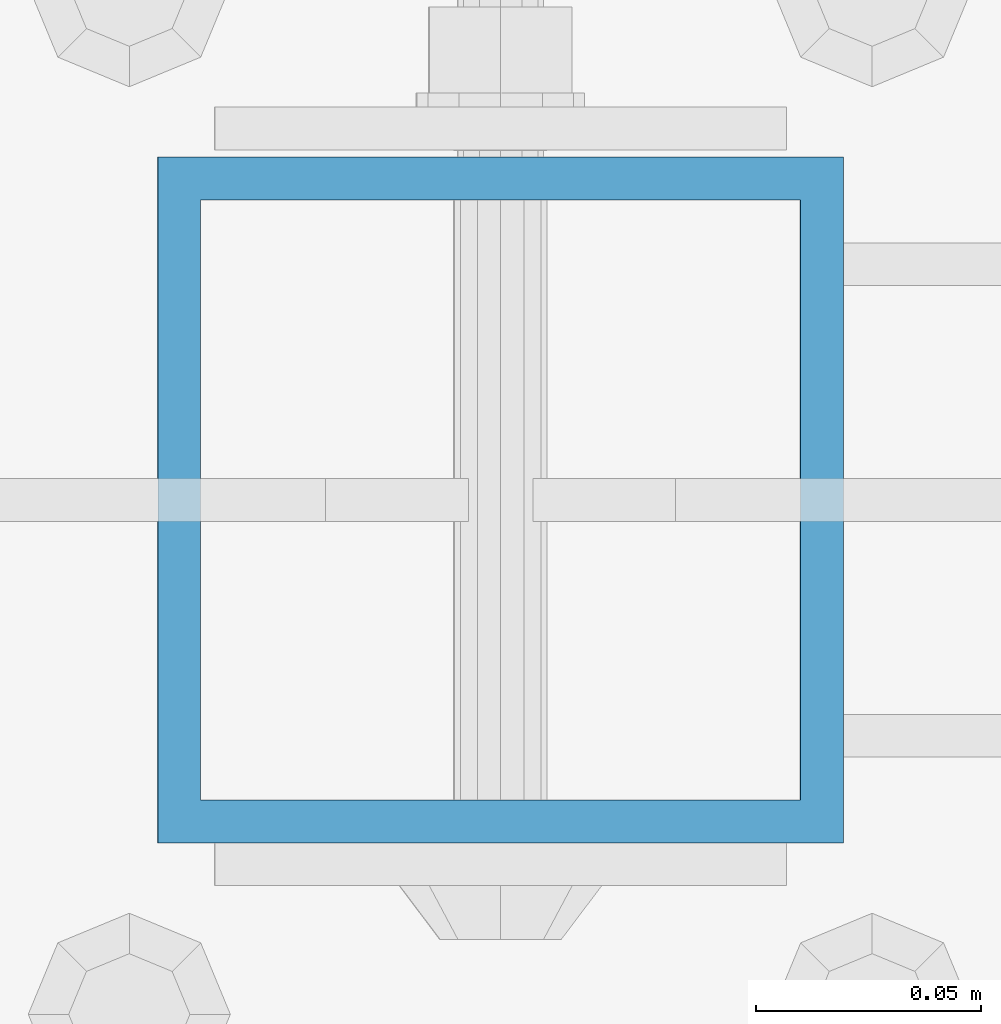
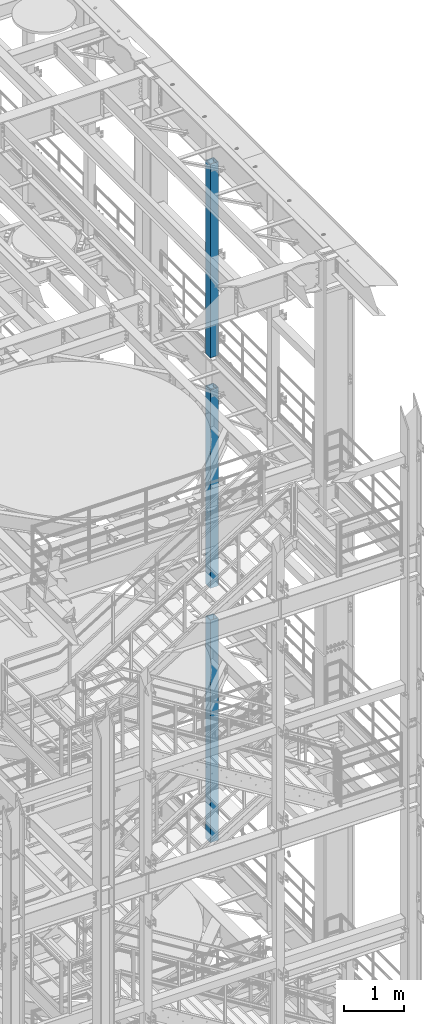
# One storey, part 709 of 1876: 3 columns, 3 elements without a shape of their own.
"""IFC2X3 building model written with IfcOpenShell, lengths in millimetres."""

from ifc_helpers import new_model, si_unit, frame, origin_with_axes, place, context, subcontext, project, spatial, faceted_brep, material, type_object, element, aggregate, save


model = new_model("IFC2X3")

# Units and contexts
model_context = context("Model", 3, precision=1e-05, world=origin_with_axes())
body_context = subcontext(model_context, "Body", "Model", "MODEL_VIEW")
ifc_project = project(units=[si_unit("LENGTHUNIT", "METRE", prefix="MILLI"), si_unit("AREAUNIT", "SQUARE_METRE"), si_unit("VOLUMEUNIT", "CUBIC_METRE"), si_unit("MASSUNIT", "GRAM", prefix="KILO"), si_unit("TIMEUNIT", "SECOND"), si_unit("PLANEANGLEUNIT", "RADIAN"), si_unit("SOLIDANGLEUNIT", "STERADIAN"), si_unit("THERMODYNAMICTEMPERATUREUNIT", "DEGREE_CELSIUS"), si_unit("LUMINOUSINTENSITYUNIT", "LUMEN")], contexts=[model_context])

# Site, building, storey
site_placement = place(None, origin_with_axes())
site = spatial("IfcSite", under=ifc_project, at=site_placement, CompositionType="ELEMENT")
building_placement = place(site_placement, origin_with_axes())
building = spatial("IfcBuilding", under=site, at=building_placement, Name="Undefined", CompositionType="ELEMENT")
storey_placement = place(building_placement, origin_with_axes())
storey = spatial("IfcBuildingStorey", under=building, at=storey_placement, Name="Undefined", CompositionType="ELEMENT", Elevation=0.0)

# Assembly, column
assembly_1_placement = place(storey_placement, origin_with_axes())
assembly_1 = element("IfcElementAssembly", 1, at=assembly_1_placement, inside=storey, Name="BEAM", AssemblyPlace="NOTDEFINED", PredefinedType="RIGID_FRAME")
ifc_material = material()
column_type = type_object("IfcColumnType", Name="HSS6X6X3/8", PredefinedType="NOTDEFINED")
column_1_placement = place(assembly_1_placement, frame((7620.0, -508.000000000001, 17983.2), z_axis=(-1.0, 0.0, 0.0), x_axis=(0.0, 0.0, 1.0)))
column_1 = element("IfcColumn", 2, at=column_1_placement, type_object=column_type, material=ifc_material, Name="COLUMN", ObjectType="HSS6X6X3/8", context=body_context, shape_type="Brep", body=[
    faceted_brep([(12.7000000000016, 66.6750000000002, -66.6750000000002), (12.7000000000016, -66.6750000000002, -66.6750000000002), (3937.0, -66.6750000000002, -66.675), (3937.0, 66.6750000000002, -66.675), (12.7000000000016, -66.6750000000002, 66.6750000000002), (3937.0, -66.6750000000002, 66.675), (12.7000000000016, 66.6750000000002, 66.6750000000002), (3937.0, 66.6750000000002, 66.675), (12.7000000000016, 76.1999999999998, -76.1999999999998), (12.7000000000016, 76.1999999999998, 76.1999999999998), (3937.0, 76.1999999999998, 76.2), (3937.0, 76.1999999999998, -76.2), (12.7000000000016, -76.1999999999998, 76.1999999999998), (3937.0, -76.1999999999998, 76.2), (12.7000000000016, -76.1999999999998, -76.1999999999998), (3937.0, -76.1999999999998, -76.2)], [[[0, 1, 2, 3]], [[1, 4, 5, 2]], [[4, 6, 7, 5]], [[6, 0, 3, 7]], [[8, 9, 10, 11]], [[9, 12, 13, 10]], [[12, 14, 15, 13]], [[14, 8, 11, 15]], [[13, 15, 11, 10], [5, 7, 3, 2]], [[14, 12, 9, 8], [6, 4, 1, 0]]]),
])
aggregate(assembly_1, [column_1])

assembly_2_placement = place(storey_placement, origin_with_axes())
assembly_2 = element("IfcElementAssembly", 3, at=assembly_2_placement, inside=storey, Name="BEAM", AssemblyPlace="NOTDEFINED", PredefinedType="RIGID_FRAME")
column_2_placement = place(assembly_2_placement, frame((7620.0, -508.000000000001, 13309.6), z_axis=(-1.0, 0.0, 0.0), x_axis=(0.0, 0.0, 1.0)))
column_2 = element("IfcColumn", 4, at=column_2_placement, type_object=column_type, material=ifc_material, Name="COLUMN", ObjectType="HSS6X6X3/8", context=body_context, shape_type="Brep", body=[
    faceted_brep([(12.7000000000016, 66.6750000000002, -66.6750000000002), (12.7000000000016, -66.6750000000002, -66.6750000000002), (4038.6, -66.6750000000002, -66.675), (4038.6, 66.6750000000002, -66.675), (12.7000000000016, -66.6750000000002, 66.6750000000002), (4038.6, -66.6750000000002, 66.675), (12.7000000000016, 66.6750000000002, 66.6750000000002), (4038.6, 66.6750000000002, 66.675), (12.7000000000016, 76.1999999999998, -76.1999999999998), (12.7000000000016, 76.1999999999998, 76.1999999999998), (4038.6, 76.1999999999998, 76.2), (4038.6, 76.1999999999998, -76.2), (12.7000000000016, -76.1999999999998, 76.1999999999998), (4038.6, -76.1999999999998, 76.2), (12.7000000000016, -76.1999999999998, -76.1999999999998), (4038.6, -76.1999999999998, -76.2)], [[[0, 1, 2, 3]], [[1, 4, 5, 2]], [[4, 6, 7, 5]], [[6, 0, 3, 7]], [[8, 9, 10, 11]], [[9, 12, 13, 10]], [[12, 14, 15, 13]], [[14, 8, 11, 15]], [[13, 15, 11, 10], [5, 7, 3, 2]], [[14, 12, 9, 8], [6, 4, 1, 0]]]),
])
aggregate(assembly_2, [column_2])

assembly_3_placement = place(storey_placement, origin_with_axes())
assembly_3 = element("IfcElementAssembly", 5, at=assembly_3_placement, inside=storey, Name="BEAM", AssemblyPlace="NOTDEFINED", PredefinedType="RIGID_FRAME")
column_3_placement = place(assembly_3_placement, frame((7620.0, -508.000000000001, 8153.4), z_axis=(-0.999999999563517, 0.0, -2.95459999870218e-05), x_axis=(-2.95459999861759e-05, 0.0, 0.999999999563517)))
column_3 = element("IfcColumn", 6, at=column_3_placement, type_object=column_type, material=ifc_material, Name="COLUMN", ObjectType="HSS6X6X3/8", context=body_context, shape_type="Brep", body=[
    faceted_brep([(12.698030025992, 66.6750000000002, -66.675), (12.698030025992, -66.6750000000002, -66.675), (4521.2007045434, -66.6750000000002, -66.675), (4521.2007045434, 66.6750000000002, -66.675), (12.7019699850925, -66.6750000000002, 66.675), (4521.20070454334, -66.6750000000002, 66.675), (12.7019699850925, 66.6750000000002, 66.675), (4521.20070454334, 66.6750000000002, 66.675), (12.6977486003425, 76.1999999999998, -76.2), (12.7022514107421, 76.1999999999998, 76.2), (4521.20070454334, 76.1999999999998, 76.2), (4521.2007045434, 76.1999999999998, -76.2), (12.7022514107421, -76.1999999999998, 76.2), (4521.20070454334, -76.1999999999998, 76.2), (12.6977486003425, -76.1999999999998, -76.2), (4521.2007045434, -76.1999999999998, -76.2)], [[[0, 1, 2, 3]], [[1, 4, 5, 2]], [[4, 6, 7, 5]], [[6, 0, 3, 7]], [[8, 9, 10, 11]], [[9, 12, 13, 10]], [[12, 14, 15, 13]], [[14, 8, 11, 15]], [[13, 15, 11, 10], [5, 7, 3, 2]], [[14, 12, 9, 8], [6, 4, 1, 0]]]),
])
aggregate(assembly_3, [column_3])

save(model, "model.ifc")
